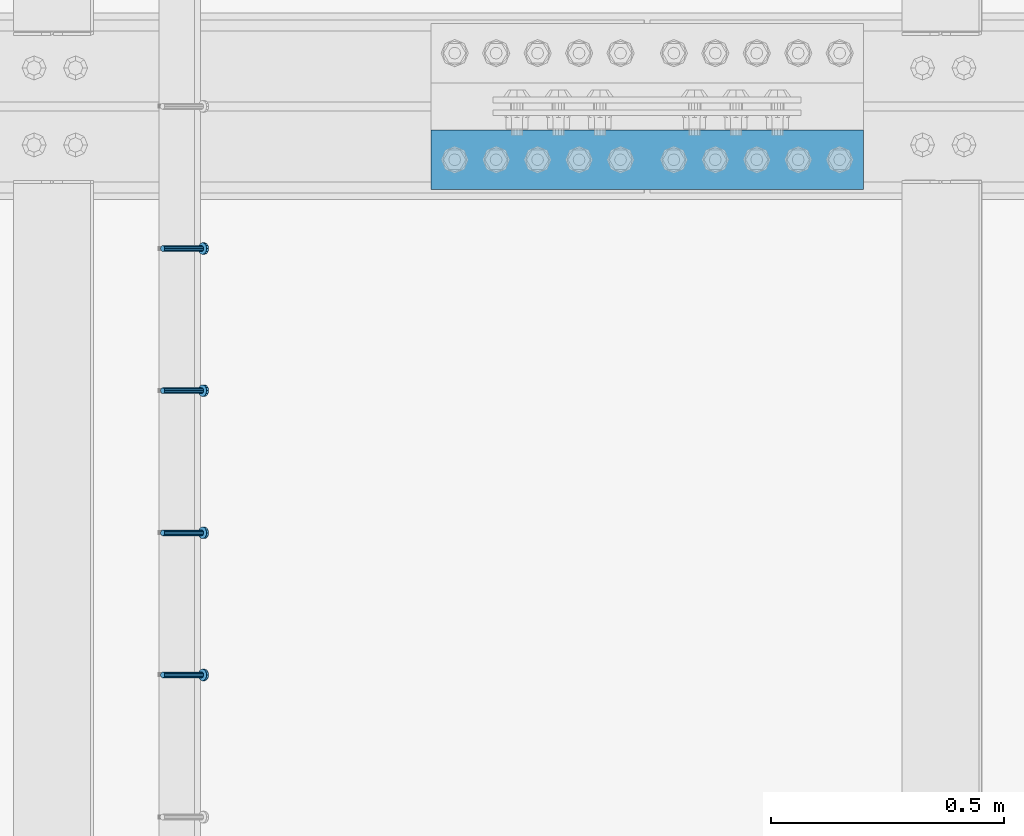
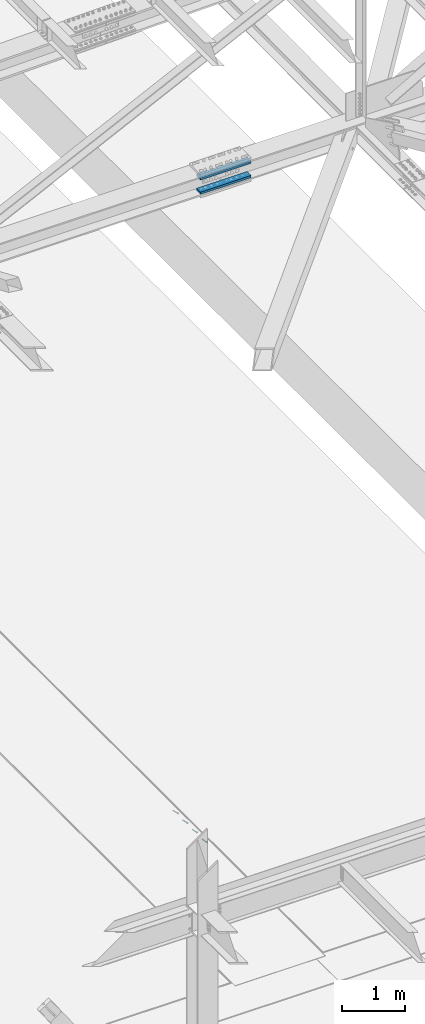
# One storey, part 2271 of 3843: 4 members, 2 beams, 2 elements without a shape of their own.
"""IFC2X3 building model written with IfcOpenShell, lengths in millimetres."""

from ifc_helpers import new_model, si_unit, frame, origin_with_axes, place, context, subcontext, project, spatial, faceted_brep, material, type_object, element, aggregate, save


model = new_model("IFC2X3")

# Units and contexts
model_context = context("Model", 3, precision=1e-05, world=origin_with_axes())
body_context = subcontext(model_context, "Body", "Model", "MODEL_VIEW")
ifc_project = project(units=[si_unit("LENGTHUNIT", "METRE", prefix="MILLI"), si_unit("AREAUNIT", "SQUARE_METRE"), si_unit("VOLUMEUNIT", "CUBIC_METRE"), si_unit("MASSUNIT", "GRAM", prefix="KILO"), si_unit("TIMEUNIT", "SECOND"), si_unit("PLANEANGLEUNIT", "RADIAN"), si_unit("SOLIDANGLEUNIT", "STERADIAN"), si_unit("THERMODYNAMICTEMPERATUREUNIT", "DEGREE_CELSIUS"), si_unit("LUMINOUSINTENSITYUNIT", "LUMEN")], contexts=[model_context])

# Site, building, storey
site_placement = place(None, origin_with_axes())
site = spatial("IfcSite", under=ifc_project, at=site_placement, CompositionType="ELEMENT")
building_placement = place(site_placement, origin_with_axes())
building = spatial("IfcBuilding", under=site, at=building_placement, Name="Undefined", CompositionType="ELEMENT")
storey_placement = place(building_placement, origin_with_axes())
storey = spatial("IfcBuildingStorey", under=building, at=storey_placement, Name="Undefined", CompositionType="ELEMENT", Elevation=0.0)

# Assembly, members
assembly_1_placement = place(storey_placement, origin_with_axes())
assembly_1 = element("IfcElementAssembly", 1, at=assembly_1_placement, inside=storey, Name="EMBED_ANGLE", AssemblyPlace="NOTDEFINED", PredefinedType="RIGID_FRAME")
ifc_material_1 = material(Name="STEEL/A108")
member_type = type_object("IfcMemberType", PredefinedType="NOTDEFINED")
member_1_placement = place(assembly_1_placement, frame((66677.3495, 32626.4271953125, 30446.6625), z_axis=(0.0, 1.0, 0.0), x_axis=(0.707106781186548, 0.0, -0.707106781186548)))
member_1 = element("IfcMember", 2, at=member_1_placement, type_object=member_type, material=ifc_material_1, Name="HEADED STUD ANCHOR", context=body_context, shape_type="Brep", body=[
    faceted_brep([(7.27595761418343e-12, -3.18000006675175, 5.5), (0.0, -5.49999999998363, 3.1800000667572), (118.110000000976, -5.49999999999091, 3.1800000667572), (118.110000000983, -3.18000006675175, 5.5), (0.0, -6.3499999046162, 0.0), (118.110000000968, -6.34999990461256, 0.0), (0.0, -5.49999999998363, -3.1800000667572), (118.110000000976, -5.49999999999091, -3.1800000667572), (7.27595761418343e-12, -3.18000006675175, -5.5), (118.110000000983, -3.18000006675175, -5.5), (7.27595761418343e-12, -1.81898940354586e-12, -6.34999990463257), (118.110000000968, -1.81898940354586e-12, -6.34999990463257), (0.0, 3.18000006675175, -5.5), (118.110000000968, 3.18000006674811, -5.5), (7.27595761418343e-12, 5.49999999998363, -3.1800000667572), (118.110000000983, 5.49999999998363, -3.1800000667572), (7.27595761418343e-12, 6.3499999046162, 0.0), (118.110000000976, 6.34999990461256, 0.0), (7.27595761418343e-12, 5.49999999998363, 3.1800000667572), (118.110000000983, 5.49999999998363, 3.1800000667572), (0.0, 3.18000006675175, 5.5), (118.110000000968, 3.18000006674811, 5.5), (7.27595761418343e-12, -1.81898940354586e-12, 6.34999990463257), (118.110000000968, -1.81898940354586e-12, 6.34999990463257), (120.650000000991, -10.9899997710909, 6.34999990463257), (120.650000000998, -6.34000015257152, 10.9899997711182), (120.650000000991, -12.6999998092379, 0.0), (120.650000000991, -10.9899997710909, -6.34999990463257), (120.650000000998, -6.34000015257152, -10.9899997711182), (120.650000000991, -1.81898940354586e-12, -12.6899995803833), (120.650000000991, 6.34000015257152, -10.9899997711182), (120.650000000998, 10.9899997710909, -6.34999990463257), (120.650000000991, 12.6999998092342, 0.0), (120.650000000998, 10.9899997710909, 6.34999990463257), (120.650000000991, 6.34000015257152, 10.9899997711182), (120.650000000991, -1.81898940354586e-12, 12.6899995803833), (127.000000001048, -10.9899997710945, 6.34999990463257), (127.000000001048, -6.34000015257152, 10.9899997711182), (127.000000001048, -12.6999998092342, 0.0), (127.000000001048, -10.9899997710945, -6.34999990463257), (127.000000001048, -6.34000015257152, -10.9899997711182), (127.000000001048, 1.81898940354586e-12, -12.6899995803833), (127.000000001048, 6.34000015256788, -10.9899997711182), (127.000000001048, 10.9899997710909, -6.34999990463257), (127.000000001048, 12.6999998092379, 0.0), (127.000000001048, 10.9899997710909, 6.34999990463257), (127.000000001048, 6.34000015256788, 10.9899997711182), (127.000000001048, 1.81898940354586e-12, 12.6899995803833)], [[[0, 1, 2, 3]], [[1, 4, 5, 2]], [[4, 6, 7, 5]], [[6, 8, 9, 7]], [[8, 10, 11, 9]], [[10, 12, 13, 11]], [[12, 14, 15, 13]], [[14, 16, 17, 15]], [[16, 18, 19, 17]], [[18, 20, 21, 19]], [[20, 22, 23, 21]], [[22, 0, 3, 23]], [[22, 20, 18, 16, 14, 12, 10, 8, 6, 4, 1, 0]], [[3, 2, 24, 25]], [[2, 5, 26, 24]], [[5, 7, 27, 26]], [[7, 9, 28, 27]], [[9, 11, 29, 28]], [[11, 13, 30, 29]], [[13, 15, 31, 30]], [[15, 17, 32, 31]], [[17, 19, 33, 32]], [[19, 21, 34, 33]], [[21, 23, 35, 34]], [[23, 3, 25, 35]], [[25, 24, 36, 37]], [[24, 26, 38, 36]], [[26, 27, 39, 38]], [[27, 28, 40, 39]], [[28, 29, 41, 40]], [[29, 30, 42, 41]], [[30, 31, 43, 42]], [[31, 32, 44, 43]], [[32, 33, 45, 44]], [[33, 34, 46, 45]], [[34, 35, 47, 46]], [[35, 25, 37, 47]], [[38, 39, 40, 41, 42, 43, 44, 45, 46, 47, 37, 36]]]),
])
member_2_placement = place(assembly_1_placement, frame((66677.3495, 32931.2271953125, 30446.6625), z_axis=(0.0, 1.0, 0.0), x_axis=(0.707106781186548, 0.0, -0.707106781186548)))
member_2 = element("IfcMember", 3, at=member_2_placement, type_object=member_type, material=ifc_material_1, Name="HEADED STUD ANCHOR", context=body_context, shape_type="Brep", body=[
    faceted_brep([(7.27595761418343e-12, -3.18000006675175, 5.5), (0.0, -5.49999999998363, 3.1800000667572), (118.110000000976, -5.49999999999091, 3.1800000667572), (118.110000000983, -3.18000006675175, 5.5), (0.0, -6.3499999046162, 0.0), (118.110000000968, -6.34999990461256, 0.0), (0.0, -5.49999999998363, -3.1800000667572), (118.110000000976, -5.49999999999091, -3.1800000667572), (7.27595761418343e-12, -3.18000006675175, -5.5), (118.110000000983, -3.18000006675175, -5.5), (7.27595761418343e-12, -1.81898940354586e-12, -6.34999990463257), (118.110000000968, -1.81898940354586e-12, -6.34999990463257), (0.0, 3.18000006675175, -5.5), (118.110000000968, 3.18000006674811, -5.5), (7.27595761418343e-12, 5.49999999998363, -3.1800000667572), (118.110000000983, 5.49999999998363, -3.1800000667572), (7.27595761418343e-12, 6.3499999046162, 0.0), (118.110000000976, 6.34999990461256, 0.0), (7.27595761418343e-12, 5.49999999998363, 3.1800000667572), (118.110000000983, 5.49999999998363, 3.1800000667572), (0.0, 3.18000006675175, 5.5), (118.110000000968, 3.18000006674811, 5.5), (7.27595761418343e-12, -1.81898940354586e-12, 6.34999990463257), (118.110000000968, -1.81898940354586e-12, 6.34999990463257), (120.650000000991, -10.9899997710909, 6.34999990463257), (120.650000000998, -6.34000015257152, 10.9899997711182), (120.650000000991, -12.6999998092379, 0.0), (120.650000000991, -10.9899997710909, -6.34999990463257), (120.650000000998, -6.34000015257152, -10.9899997711182), (120.650000000991, -1.81898940354586e-12, -12.6899995803833), (120.650000000991, 6.34000015257152, -10.9899997711182), (120.650000000998, 10.9899997710909, -6.34999990463257), (120.650000000991, 12.6999998092342, 0.0), (120.650000000998, 10.9899997710909, 6.34999990463257), (120.650000000991, 6.34000015257152, 10.9899997711182), (120.650000000991, -1.81898940354586e-12, 12.6899995803833), (127.000000001048, -10.9899997710945, 6.34999990463257), (127.000000001048, -6.34000015257152, 10.9899997711182), (127.000000001048, -12.6999998092342, 0.0), (127.000000001048, -10.9899997710945, -6.34999990463257), (127.000000001048, -6.34000015257152, -10.9899997711182), (127.000000001048, 1.81898940354586e-12, -12.6899995803833), (127.000000001048, 6.34000015256788, -10.9899997711182), (127.000000001048, 10.9899997710909, -6.34999990463257), (127.000000001048, 12.6999998092379, 0.0), (127.000000001048, 10.9899997710909, 6.34999990463257), (127.000000001048, 6.34000015256788, 10.9899997711182), (127.000000001048, 1.81898940354586e-12, 12.6899995803833)], [[[0, 1, 2, 3]], [[1, 4, 5, 2]], [[4, 6, 7, 5]], [[6, 8, 9, 7]], [[8, 10, 11, 9]], [[10, 12, 13, 11]], [[12, 14, 15, 13]], [[14, 16, 17, 15]], [[16, 18, 19, 17]], [[18, 20, 21, 19]], [[20, 22, 23, 21]], [[22, 0, 3, 23]], [[22, 20, 18, 16, 14, 12, 10, 8, 6, 4, 1, 0]], [[3, 2, 24, 25]], [[2, 5, 26, 24]], [[5, 7, 27, 26]], [[7, 9, 28, 27]], [[9, 11, 29, 28]], [[11, 13, 30, 29]], [[13, 15, 31, 30]], [[15, 17, 32, 31]], [[17, 19, 33, 32]], [[19, 21, 34, 33]], [[21, 23, 35, 34]], [[23, 3, 25, 35]], [[25, 24, 36, 37]], [[24, 26, 38, 36]], [[26, 27, 39, 38]], [[27, 28, 40, 39]], [[28, 29, 41, 40]], [[29, 30, 42, 41]], [[30, 31, 43, 42]], [[31, 32, 44, 43]], [[32, 33, 45, 44]], [[33, 34, 46, 45]], [[34, 35, 47, 46]], [[35, 25, 37, 47]], [[38, 39, 40, 41, 42, 43, 44, 45, 46, 47, 37, 36]]]),
])
member_3_placement = place(assembly_1_placement, frame((66677.3495, 33236.0271953125, 30446.6625), z_axis=(0.0, 1.0, 0.0), x_axis=(0.707106781186548, 0.0, -0.707106781186548)))
member_3 = element("IfcMember", 4, at=member_3_placement, type_object=member_type, material=ifc_material_1, Name="HEADED STUD ANCHOR", context=body_context, shape_type="Brep", body=[
    faceted_brep([(7.27595761418343e-12, -3.18000006675175, 5.5), (0.0, -5.49999999998363, 3.1800000667572), (118.110000000976, -5.49999999999091, 3.1800000667572), (118.110000000983, -3.18000006675175, 5.5), (0.0, -6.3499999046162, 0.0), (118.110000000968, -6.34999990461256, 0.0), (0.0, -5.49999999998363, -3.1800000667572), (118.110000000976, -5.49999999999091, -3.1800000667572), (7.27595761418343e-12, -3.18000006675175, -5.5), (118.110000000983, -3.18000006675175, -5.5), (7.27595761418343e-12, -1.81898940354586e-12, -6.34999990463257), (118.110000000968, -1.81898940354586e-12, -6.34999990463257), (0.0, 3.18000006675175, -5.5), (118.110000000968, 3.18000006674811, -5.5), (7.27595761418343e-12, 5.49999999998363, -3.1800000667572), (118.110000000983, 5.49999999998363, -3.1800000667572), (7.27595761418343e-12, 6.3499999046162, 0.0), (118.110000000976, 6.34999990461256, 0.0), (7.27595761418343e-12, 5.49999999998363, 3.1800000667572), (118.110000000983, 5.49999999998363, 3.1800000667572), (0.0, 3.18000006675175, 5.5), (118.110000000968, 3.18000006674811, 5.5), (7.27595761418343e-12, -1.81898940354586e-12, 6.34999990463257), (118.110000000968, -1.81898940354586e-12, 6.34999990463257), (120.650000000991, -10.9899997710909, 6.34999990463257), (120.650000000998, -6.34000015257152, 10.9899997711182), (120.650000000991, -12.6999998092379, 0.0), (120.650000000991, -10.9899997710909, -6.34999990463257), (120.650000000998, -6.34000015257152, -10.9899997711182), (120.650000000991, -1.81898940354586e-12, -12.6899995803833), (120.650000000991, 6.34000015257152, -10.9899997711182), (120.650000000998, 10.9899997710909, -6.34999990463257), (120.650000000991, 12.6999998092342, 0.0), (120.650000000998, 10.9899997710909, 6.34999990463257), (120.650000000991, 6.34000015257152, 10.9899997711182), (120.650000000991, -1.81898940354586e-12, 12.6899995803833), (127.000000001048, -10.9899997710945, 6.34999990463257), (127.000000001048, -6.34000015257152, 10.9899997711182), (127.000000001048, -12.6999998092342, 0.0), (127.000000001048, -10.9899997710945, -6.34999990463257), (127.000000001048, -6.34000015257152, -10.9899997711182), (127.000000001048, 1.81898940354586e-12, -12.6899995803833), (127.000000001048, 6.34000015256788, -10.9899997711182), (127.000000001048, 10.9899997710909, -6.34999990463257), (127.000000001048, 12.6999998092379, 0.0), (127.000000001048, 10.9899997710909, 6.34999990463257), (127.000000001048, 6.34000015256788, 10.9899997711182), (127.000000001048, 1.81898940354586e-12, 12.6899995803833)], [[[0, 1, 2, 3]], [[1, 4, 5, 2]], [[4, 6, 7, 5]], [[6, 8, 9, 7]], [[8, 10, 11, 9]], [[10, 12, 13, 11]], [[12, 14, 15, 13]], [[14, 16, 17, 15]], [[16, 18, 19, 17]], [[18, 20, 21, 19]], [[20, 22, 23, 21]], [[22, 0, 3, 23]], [[22, 20, 18, 16, 14, 12, 10, 8, 6, 4, 1, 0]], [[3, 2, 24, 25]], [[2, 5, 26, 24]], [[5, 7, 27, 26]], [[7, 9, 28, 27]], [[9, 11, 29, 28]], [[11, 13, 30, 29]], [[13, 15, 31, 30]], [[15, 17, 32, 31]], [[17, 19, 33, 32]], [[19, 21, 34, 33]], [[21, 23, 35, 34]], [[23, 3, 25, 35]], [[25, 24, 36, 37]], [[24, 26, 38, 36]], [[26, 27, 39, 38]], [[27, 28, 40, 39]], [[28, 29, 41, 40]], [[29, 30, 42, 41]], [[30, 31, 43, 42]], [[31, 32, 44, 43]], [[32, 33, 45, 44]], [[33, 34, 46, 45]], [[34, 35, 47, 46]], [[35, 25, 37, 47]], [[38, 39, 40, 41, 42, 43, 44, 45, 46, 47, 37, 36]]]),
])
member_4_placement = place(assembly_1_placement, frame((66677.3495, 33540.8271953125, 30446.6625), z_axis=(0.0, 1.0, 0.0), x_axis=(0.707106781186548, 0.0, -0.707106781186548)))
member_4 = element("IfcMember", 5, at=member_4_placement, type_object=member_type, material=ifc_material_1, Name="HEADED STUD ANCHOR", context=body_context, shape_type="Brep", body=[
    faceted_brep([(7.27595761418343e-12, -3.18000006675175, 5.5), (0.0, -5.49999999998363, 3.1800000667572), (118.110000000976, -5.49999999999091, 3.1800000667572), (118.110000000983, -3.18000006675175, 5.5), (0.0, -6.3499999046162, 0.0), (118.110000000968, -6.34999990461256, 0.0), (0.0, -5.49999999998363, -3.1800000667572), (118.110000000976, -5.49999999999091, -3.1800000667572), (7.27595761418343e-12, -3.18000006675175, -5.5), (118.110000000983, -3.18000006675175, -5.5), (7.27595761418343e-12, -1.81898940354586e-12, -6.34999990463257), (118.110000000968, -1.81898940354586e-12, -6.34999990463257), (0.0, 3.18000006675175, -5.5), (118.110000000968, 3.18000006674811, -5.5), (7.27595761418343e-12, 5.49999999998363, -3.1800000667572), (118.110000000983, 5.49999999998363, -3.1800000667572), (7.27595761418343e-12, 6.3499999046162, 0.0), (118.110000000976, 6.34999990461256, 0.0), (7.27595761418343e-12, 5.49999999998363, 3.1800000667572), (118.110000000983, 5.49999999998363, 3.1800000667572), (0.0, 3.18000006675175, 5.5), (118.110000000968, 3.18000006674811, 5.5), (7.27595761418343e-12, -1.81898940354586e-12, 6.34999990463257), (118.110000000968, -1.81898940354586e-12, 6.34999990463257), (120.650000000991, -10.9899997710909, 6.34999990463257), (120.650000000998, -6.34000015257152, 10.9899997711182), (120.650000000991, -12.6999998092379, 0.0), (120.650000000991, -10.9899997710909, -6.34999990463257), (120.650000000998, -6.34000015257152, -10.9899997711182), (120.650000000991, -1.81898940354586e-12, -12.6899995803833), (120.650000000991, 6.34000015257152, -10.9899997711182), (120.650000000998, 10.9899997710909, -6.34999990463257), (120.650000000991, 12.6999998092342, 0.0), (120.650000000998, 10.9899997710909, 6.34999990463257), (120.650000000991, 6.34000015257152, 10.9899997711182), (120.650000000991, -1.81898940354586e-12, 12.6899995803833), (127.000000001048, -10.9899997710945, 6.34999990463257), (127.000000001048, -6.34000015257152, 10.9899997711182), (127.000000001048, -12.6999998092342, 0.0), (127.000000001048, -10.9899997710945, -6.34999990463257), (127.000000001048, -6.34000015257152, -10.9899997711182), (127.000000001048, 1.81898940354586e-12, -12.6899995803833), (127.000000001048, 6.34000015256788, -10.9899997711182), (127.000000001048, 10.9899997710909, -6.34999990463257), (127.000000001048, 12.6999998092379, 0.0), (127.000000001048, 10.9899997710909, 6.34999990463257), (127.000000001048, 6.34000015256788, 10.9899997711182), (127.000000001048, 1.81898940354586e-12, 12.6899995803833)], [[[0, 1, 2, 3]], [[1, 4, 5, 2]], [[4, 6, 7, 5]], [[6, 8, 9, 7]], [[8, 10, 11, 9]], [[10, 12, 13, 11]], [[12, 14, 15, 13]], [[14, 16, 17, 15]], [[16, 18, 19, 17]], [[18, 20, 21, 19]], [[20, 22, 23, 21]], [[22, 0, 3, 23]], [[22, 20, 18, 16, 14, 12, 10, 8, 6, 4, 1, 0]], [[3, 2, 24, 25]], [[2, 5, 26, 24]], [[5, 7, 27, 26]], [[7, 9, 28, 27]], [[9, 11, 29, 28]], [[11, 13, 30, 29]], [[13, 15, 31, 30]], [[15, 17, 32, 31]], [[17, 19, 33, 32]], [[19, 21, 34, 33]], [[21, 23, 35, 34]], [[23, 3, 25, 35]], [[25, 24, 36, 37]], [[24, 26, 38, 36]], [[26, 27, 39, 38]], [[27, 28, 40, 39]], [[28, 29, 41, 40]], [[29, 30, 42, 41]], [[30, 31, 43, 42]], [[31, 32, 44, 43]], [[32, 33, 45, 44]], [[33, 34, 46, 45]], [[34, 35, 47, 46]], [[35, 25, 37, 47]], [[38, 39, 40, 41, 42, 43, 44, 45, 46, 47, 37, 36]]]),
])
aggregate(assembly_1, [member_1, member_2, member_3, member_4])

# Assembly, beams
assembly_2_placement = place(storey_placement, origin_with_axes())
assembly_2 = element("IfcElementAssembly", 6, at=assembly_2_placement, inside=storey, Name="BEAM", AssemblyPlace="NOTDEFINED", PredefinedType="RIGID_FRAME")
ifc_material_2 = material(Name="STEEL/A572-50")
beam_type = type_object("IfcBeamType", PredefinedType="NOTDEFINED")
beam_1_placement = place(assembly_2_placement, frame((67252.783371169, 33731.2, 42399.4737289585), z_axis=(0.0, 1.0, 0.0), x_axis=(0.999999883444831, 0.0, 0.000482815000217081)))
beam_1 = element("IfcBeam", 7, at=beam_1_placement, type_object=beam_type, material=ifc_material_2, Name="PLATE", context=body_context, shape_type="Brep", body=[
    faceted_brep([(-7.27595761418343e-11, 22.2250000000786, -63.5), (-7.27595761418343e-11, 22.2250000000786, 63.5), (927.099999951592, 22.2250000031054, 63.5), (927.099999951592, 22.2250000031054, -63.5), (6.54836185276508e-11, -22.2250000000713, 63.5), (927.099999951744, -22.2249999970372, 63.5), (6.54836185276508e-11, -22.2250000000713, -63.5), (927.099999951744, -22.2249999970372, -63.5)], [[[0, 1, 2, 3]], [[1, 4, 5, 2]], [[4, 6, 7, 5]], [[6, 0, 3, 7]], [[5, 7, 3, 2]], [[6, 4, 1, 0]]]),
])
beam_2_placement = place(assembly_2_placement, frame((67252.9167367417, 33731.2, 42123.2487611883), z_axis=(0.0, 1.0, 0.0), x_axis=(0.999999883444831, 0.0, 0.000482815000217081)))
beam_2 = element("IfcBeam", 8, at=beam_2_placement, type_object=beam_type, material=ifc_material_2, Name="PLATE", context=body_context, shape_type="Brep", body=[
    faceted_brep([(-7.27595761418343e-11, 22.2250000000786, -63.5), (-7.27595761418343e-11, 22.2250000000786, 63.5), (927.099999951592, 22.2250000031054, 63.5), (927.099999951592, 22.2250000031054, -63.5), (6.54836185276508e-11, -22.2250000000713, 63.5), (927.099999951744, -22.2249999970372, 63.5), (6.54836185276508e-11, -22.2250000000713, -63.5), (927.099999951744, -22.2249999970372, -63.5)], [[[0, 1, 2, 3]], [[1, 4, 5, 2]], [[4, 6, 7, 5]], [[6, 0, 3, 7]], [[5, 7, 3, 2]], [[6, 4, 1, 0]]]),
])
aggregate(assembly_2, [beam_1, beam_2])

save(model, "model.ifc")
